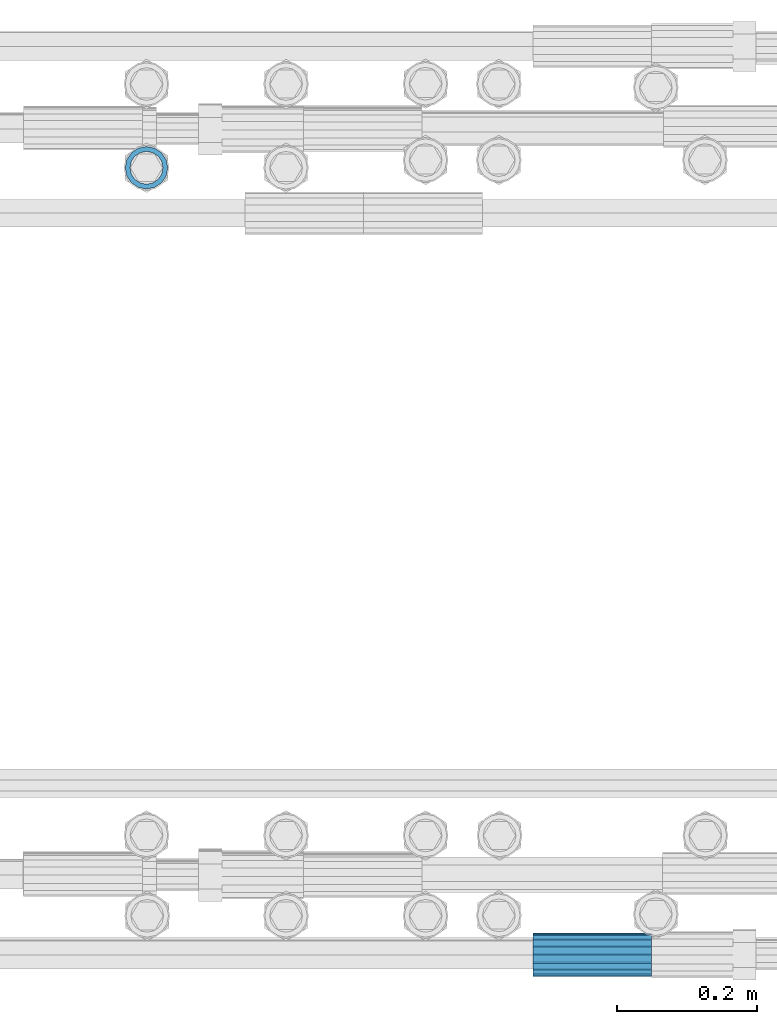
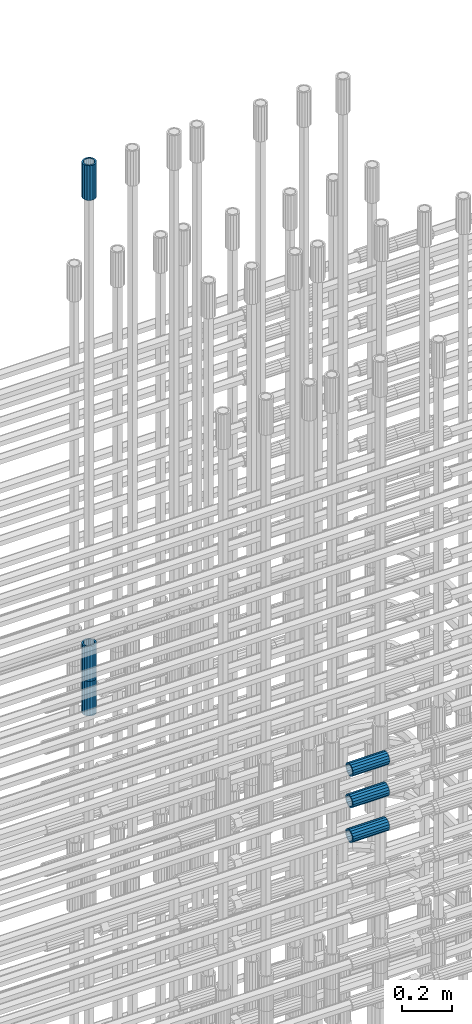
# One storey, part 29 of 119: 6 beams.
"""IFC2X3 building model written with IfcOpenShell, lengths in millimetres."""

from ifc_helpers import new_model, si_unit, frame, origin_with_axes, place, context, subcontext, project, spatial, faceted_brep, material, type_object, element, save


model = new_model("IFC2X3")

# Units and contexts
model_context = context("Model", 3, precision=1e-05, world=origin_with_axes())
body_context = subcontext(model_context, "Body", "Model", "MODEL_VIEW")
ifc_project = project(units=[si_unit("LENGTHUNIT", "METRE", prefix="MILLI"), si_unit("AREAUNIT", "SQUARE_METRE"), si_unit("VOLUMEUNIT", "CUBIC_METRE"), si_unit("MASSUNIT", "GRAM", prefix="KILO"), si_unit("TIMEUNIT", "SECOND"), si_unit("PLANEANGLEUNIT", "RADIAN"), si_unit("SOLIDANGLEUNIT", "STERADIAN"), si_unit("THERMODYNAMICTEMPERATUREUNIT", "DEGREE_CELSIUS"), si_unit("LUMINOUSINTENSITYUNIT", "LUMEN")], contexts=[model_context])

# Site, building, storey
site_placement = place(None, origin_with_axes())
site = spatial("IfcSite", under=ifc_project, at=site_placement, CompositionType="ELEMENT")
building_placement = place(site_placement, origin_with_axes())
building = spatial("IfcBuilding", under=site, at=building_placement, Name="Undefined", CompositionType="ELEMENT")
storey_placement = place(building_placement, origin_with_axes())
storey = spatial("IfcBuildingStorey", under=building, at=storey_placement, Name="Undefined", CompositionType="ELEMENT", Elevation=0.0)

# Beams
ifc_material = material(Name="STEEL/S275")
beam_type = type_object("IfcBeamType", PredefinedType="NOTDEFINED")
beam_1_placement = place(storey_placement, frame((2035124.99756192, 6206225.98580115, 23229.965729164), z_axis=(1.0, 0.0, 0.0), x_axis=(0.0, 0.0, 1.0)))
element("IfcBeam", 1, at=beam_1_placement, inside=storey, type_object=beam_type, material=ifc_material, Name="AG40N", context=body_context, shape_type="Brep", body=[
    faceted_brep([(1.62981450557709e-09, -23.4999999990687, 0.0), (7.45058059692383e-09, -21.7111690142192, 8.99306066057534), (170.000002125278, -21.711168999318, 8.99306066022245), (170.000002127141, -23.4999999844003, -3.66071617463604e-10), (4.65661287307739e-09, -16.6170093587134, 16.6170093578889), (170.000002122484, -16.6170093440451, 16.6170093575288), (1.86264514923096e-09, -8.99306066217832, 21.7111690140277), (170.000002118759, -8.99306064750999, 21.7111690136603), (2.3283064365387e-10, 9.31322574615479e-10, 23.5), (170.000002114102, 1.28056854009628e-08, 23.4999999996485), (-6.51925802230835e-09, 8.99306065868586, 21.7111690140241), (170.00000211224, 8.99306067335419, 21.7111690136639), (-7.45058059692383e-09, 16.6170093561523, 16.6170093578853), (170.000002109446, 16.6170093708206, 16.6170093575324), (-9.31322574615479e-09, 21.711169013055, 8.99306066057534), (170.000002108514, 21.7111690277234, 8.99306066022245), (-1.16415321826935e-09, 23.5000000009313, 0.0), (170.000002108514, 23.5000000144355, -3.66071617463604e-10), (-8.38190317153931e-09, 21.7111690151505, -8.99306066059444), (170.000002110377, 21.7111690300517, -8.9930606609546), (-5.58793544769287e-09, 16.6170093598776, -16.6170093579008), (170.000002113171, 16.6170093745459, -16.6170093582609), (-9.31322574615479e-10, 8.99306066334248, -21.7111690140396), (170.000002115965, 8.99306067801081, -21.7111690143961), (2.3283064365387e-10, 9.31322574615479e-10, -23.5), (170.00000211969, 1.7927959561348e-08, -23.5000000003843), (5.58793544769287e-09, -8.99306065752171, -21.7111690140396), (170.000002123415, -8.99306064285338, -21.7111690143961), (8.38190317153931e-09, -16.6170093549881, -16.6170093579008), (170.000002125278, -16.6170093403198, -16.6170093582646), (9.31322574615479e-09, -21.7111690121237, -8.99306066059444), (170.000002127141, -21.7111689972226, -8.9930606609546), (1.11758708953857e-08, -30.4999999990687, -9.54969436861575e-12), (1.30385160446167e-08, -28.1783257392235, -11.6718446871514), (170.000002129003, -28.1783257243223, -11.6718446875116), (170.000002129935, -30.4999999841675, -3.66071617463604e-10), (1.02445483207703e-08, -21.5667568228673, -21.5667568262129), (170.000002128072, -21.566756808199, -21.5667568265694), (7.45058059692383e-09, -11.6718446831219, -28.1783257416196), (170.000002125278, -11.6718446684536, -28.1783257419834), (3.72529029846191e-09, 3.95812094211578e-09, -30.5000000000277), (170.00000211969, 1.83936208486557e-08, -30.5000000003879), (-9.31322574615479e-10, 11.6718446905725, -28.1783257416232), (170.000002115965, 11.6718447052408, -28.1783257419797), (-6.51925802230835e-09, 21.5667568286881, -21.5667568262093), (170.000002110377, 21.5667568433564, -21.5667568265694), (-9.31322574615479e-09, 28.178325742716, -11.6718446871478), (170.000002108514, 28.1783257573843, -11.6718446875079), (-1.21071934700012e-08, 30.5, -5.91171556152403e-12), (170.000002106652, 30.5000000144355, -3.62433638656512e-10), (-1.21071934700012e-08, 28.1783257401548, 11.6718446871359), (170.00000210572, 28.1783257548232, 11.6718446867794), (-1.02445483207703e-08, 21.5667568240315, 21.5667568261974), (170.000002107583, 21.566756838467, 21.5667568258409), (-7.45058059692383e-09, 11.671844684286, 28.1783257416041), (170.000002110377, 11.6718446989544, 28.178325741244), (-2.79396772384644e-09, -2.56113708019257e-09, 30.5000000000159), (170.000002114102, 1.18743628263474e-08, 30.4999999996558), (1.86264514923096e-09, -11.6718446896411, 28.1783257416114), (170.000002118759, -11.67184467474, 28.178325741244), (7.45058059692383e-09, -21.5667568275239, 21.5667568261974), (170.000002123415, -21.5667568126228, 21.5667568258373), (1.02445483207703e-08, -28.1783257415518, 11.6718446871359), (170.000002127141, -28.1783257271163, 11.6718446867794)], [[[0, 1, 2, 3]], [[1, 4, 5, 2]], [[4, 6, 7, 5]], [[6, 8, 9, 7]], [[8, 10, 11, 9]], [[10, 12, 13, 11]], [[12, 14, 15, 13]], [[14, 16, 17, 15]], [[16, 18, 19, 17]], [[18, 20, 21, 19]], [[20, 22, 23, 21]], [[22, 24, 25, 23]], [[24, 26, 27, 25]], [[26, 28, 29, 27]], [[28, 30, 31, 29]], [[30, 0, 3, 31]], [[32, 33, 34, 35]], [[33, 36, 37, 34]], [[36, 38, 39, 37]], [[38, 40, 41, 39]], [[40, 42, 43, 41]], [[42, 44, 45, 43]], [[44, 46, 47, 45]], [[46, 48, 49, 47]], [[48, 50, 51, 49]], [[50, 52, 53, 51]], [[52, 54, 55, 53]], [[54, 56, 57, 55]], [[56, 58, 59, 57]], [[58, 60, 61, 59]], [[60, 62, 63, 61]], [[62, 32, 35, 63]], [[37, 39, 41, 43, 45, 47, 49, 51, 53, 55, 57, 59, 61, 63, 35, 34], [5, 7, 9, 11, 13, 15, 17, 19, 21, 23, 25, 27, 29, 31, 3, 2]], [[62, 60, 58, 56, 54, 52, 50, 48, 46, 44, 42, 40, 38, 36, 33, 32], [30, 28, 26, 24, 22, 20, 18, 16, 14, 12, 10, 8, 6, 4, 1, 0]]]),
])
beam_2_placement = place(storey_placement, frame((2035124.99756192, 6206225.98580116, 21044.6068583145), z_axis=(-0.99999999999998, 1.98000110685822e-07, 0.0), x_axis=(0.0, 0.0, -1.0)))
element("IfcBeam", 2, at=beam_2_placement, inside=storey, type_object=beam_type, material=ifc_material, Name="AG40N", context=body_context, shape_type="Brep", body=[
    faceted_brep([(1.62981450557709e-09, -23.4999999990687, 0.0), (7.45058059692383e-09, -21.7111690142192, 8.99306066057534), (170.000002125278, -21.711168999318, 8.99306066022245), (170.000002127141, -23.4999999844003, -3.66071617463604e-10), (4.65661287307739e-09, -16.6170093587134, 16.6170093578889), (170.000002122484, -16.6170093440451, 16.6170093575288), (1.86264514923096e-09, -8.99306066217832, 21.7111690140277), (170.000002118759, -8.99306064750999, 21.7111690136603), (2.3283064365387e-10, 9.31322574615479e-10, 23.5), (170.000002114102, 1.28056854009628e-08, 23.4999999996485), (-6.51925802230835e-09, 8.99306065868586, 21.7111690140241), (170.00000211224, 8.99306067335419, 21.7111690136639), (-7.45058059692383e-09, 16.6170093561523, 16.6170093578853), (170.000002109446, 16.6170093708206, 16.6170093575324), (-9.31322574615479e-09, 21.711169013055, 8.99306066057534), (170.000002108514, 21.7111690277234, 8.99306066022245), (-1.16415321826935e-09, 23.5000000009313, 0.0), (170.000002108514, 23.5000000144355, -3.66071617463604e-10), (-8.38190317153931e-09, 21.7111690151505, -8.99306066059444), (170.000002110377, 21.7111690300517, -8.9930606609546), (-5.58793544769287e-09, 16.6170093598776, -16.6170093579008), (170.000002113171, 16.6170093745459, -16.6170093582609), (-9.31322574615479e-10, 8.99306066334248, -21.7111690140396), (170.000002115965, 8.99306067801081, -21.7111690143961), (2.3283064365387e-10, 9.31322574615479e-10, -23.5), (170.00000211969, 1.7927959561348e-08, -23.5000000003843), (5.58793544769287e-09, -8.99306065752171, -21.7111690140396), (170.000002123415, -8.99306064285338, -21.7111690143961), (8.38190317153931e-09, -16.6170093549881, -16.6170093579008), (170.000002125278, -16.6170093403198, -16.6170093582646), (9.31322574615479e-09, -21.7111690121237, -8.99306066059444), (170.000002127141, -21.7111689972226, -8.9930606609546), (1.11758708953857e-08, -30.4999999990687, -9.54969436861575e-12), (1.30385160446167e-08, -28.1783257392235, -11.6718446871514), (170.000002129003, -28.1783257243223, -11.6718446875116), (170.000002129935, -30.4999999841675, -3.66071617463604e-10), (1.02445483207703e-08, -21.5667568228673, -21.5667568262129), (170.000002128072, -21.566756808199, -21.5667568265694), (7.45058059692383e-09, -11.6718446831219, -28.1783257416196), (170.000002125278, -11.6718446684536, -28.1783257419834), (3.72529029846191e-09, 3.95812094211578e-09, -30.5000000000277), (170.00000211969, 1.83936208486557e-08, -30.5000000003879), (-9.31322574615479e-10, 11.6718446905725, -28.1783257416232), (170.000002115965, 11.6718447052408, -28.1783257419797), (-6.51925802230835e-09, 21.5667568286881, -21.5667568262093), (170.000002110377, 21.5667568433564, -21.5667568265694), (-9.31322574615479e-09, 28.178325742716, -11.6718446871478), (170.000002108514, 28.1783257573843, -11.6718446875079), (-1.21071934700012e-08, 30.5, -5.91171556152403e-12), (170.000002106652, 30.5000000144355, -3.62433638656512e-10), (-1.21071934700012e-08, 28.1783257401548, 11.6718446871359), (170.00000210572, 28.1783257548232, 11.6718446867794), (-1.02445483207703e-08, 21.5667568240315, 21.5667568261974), (170.000002107583, 21.566756838467, 21.5667568258409), (-7.45058059692383e-09, 11.671844684286, 28.1783257416041), (170.000002110377, 11.6718446989544, 28.178325741244), (-2.79396772384644e-09, -2.56113708019257e-09, 30.5000000000159), (170.000002114102, 1.18743628263474e-08, 30.4999999996558), (1.86264514923096e-09, -11.6718446896411, 28.1783257416114), (170.000002118759, -11.67184467474, 28.178325741244), (7.45058059692383e-09, -21.5667568275239, 21.5667568261974), (170.000002123415, -21.5667568126228, 21.5667568258373), (1.02445483207703e-08, -28.1783257415518, 11.6718446871359), (170.000002127141, -28.1783257271163, 11.6718446867794)], [[[0, 1, 2, 3]], [[1, 4, 5, 2]], [[4, 6, 7, 5]], [[6, 8, 9, 7]], [[8, 10, 11, 9]], [[10, 12, 13, 11]], [[12, 14, 15, 13]], [[14, 16, 17, 15]], [[16, 18, 19, 17]], [[18, 20, 21, 19]], [[20, 22, 23, 21]], [[22, 24, 25, 23]], [[24, 26, 27, 25]], [[26, 28, 29, 27]], [[28, 30, 31, 29]], [[30, 0, 3, 31]], [[32, 33, 34, 35]], [[33, 36, 37, 34]], [[36, 38, 39, 37]], [[38, 40, 41, 39]], [[40, 42, 43, 41]], [[42, 44, 45, 43]], [[44, 46, 47, 45]], [[46, 48, 49, 47]], [[48, 50, 51, 49]], [[50, 52, 53, 51]], [[52, 54, 55, 53]], [[54, 56, 57, 55]], [[56, 58, 59, 57]], [[58, 60, 61, 59]], [[60, 62, 63, 61]], [[62, 32, 35, 63]], [[37, 39, 41, 43, 45, 47, 49, 51, 53, 55, 57, 59, 61, 63, 35, 34], [5, 7, 9, 11, 13, 15, 17, 19, 21, 23, 25, 27, 29, 31, 3, 2]], [[62, 60, 58, 56, 54, 52, 50, 48, 46, 44, 42, 40, 38, 36, 33, 32], [30, 28, 26, 24, 22, 20, 18, 16, 14, 12, 10, 8, 6, 4, 1, 0]]]),
])
beam_3_placement = place(storey_placement, frame((2035124.99756192, 6206225.98580115, 20704.605729164), z_axis=(1.0, 0.0, 0.0), x_axis=(0.0, 0.0, 1.0)))
element("IfcBeam", 3, at=beam_3_placement, inside=storey, type_object=beam_type, material=ifc_material, Name="AG40N", context=body_context, shape_type="Brep", body=[
    faceted_brep([(1.62981450557709e-09, -23.4999999990687, 0.0), (7.45058059692383e-09, -21.7111690142192, 8.99306066057534), (170.000002125278, -21.711168999318, 8.99306066022245), (170.000002127141, -23.4999999844003, -3.66071617463604e-10), (4.65661287307739e-09, -16.6170093587134, 16.6170093578889), (170.000002122484, -16.6170093440451, 16.6170093575288), (1.86264514923096e-09, -8.99306066217832, 21.7111690140277), (170.000002118759, -8.99306064750999, 21.7111690136603), (2.3283064365387e-10, 9.31322574615479e-10, 23.5), (170.000002114102, 1.28056854009628e-08, 23.4999999996485), (-6.51925802230835e-09, 8.99306065868586, 21.7111690140241), (170.00000211224, 8.99306067335419, 21.7111690136639), (-7.45058059692383e-09, 16.6170093561523, 16.6170093578853), (170.000002109446, 16.6170093708206, 16.6170093575324), (-9.31322574615479e-09, 21.711169013055, 8.99306066057534), (170.000002108514, 21.7111690277234, 8.99306066022245), (-1.16415321826935e-09, 23.5000000009313, 0.0), (170.000002108514, 23.5000000144355, -3.66071617463604e-10), (-8.38190317153931e-09, 21.7111690151505, -8.99306066059444), (170.000002110377, 21.7111690300517, -8.9930606609546), (-5.58793544769287e-09, 16.6170093598776, -16.6170093579008), (170.000002113171, 16.6170093745459, -16.6170093582609), (-9.31322574615479e-10, 8.99306066334248, -21.7111690140396), (170.000002115965, 8.99306067801081, -21.7111690143961), (2.3283064365387e-10, 9.31322574615479e-10, -23.5), (170.00000211969, 1.7927959561348e-08, -23.5000000003843), (5.58793544769287e-09, -8.99306065752171, -21.7111690140396), (170.000002123415, -8.99306064285338, -21.7111690143961), (8.38190317153931e-09, -16.6170093549881, -16.6170093579008), (170.000002125278, -16.6170093403198, -16.6170093582646), (9.31322574615479e-09, -21.7111690121237, -8.99306066059444), (170.000002127141, -21.7111689972226, -8.9930606609546), (1.11758708953857e-08, -30.4999999990687, -9.54969436861575e-12), (1.30385160446167e-08, -28.1783257392235, -11.6718446871514), (170.000002129003, -28.1783257243223, -11.6718446875116), (170.000002129935, -30.4999999841675, -3.66071617463604e-10), (1.02445483207703e-08, -21.5667568228673, -21.5667568262129), (170.000002128072, -21.566756808199, -21.5667568265694), (7.45058059692383e-09, -11.6718446831219, -28.1783257416196), (170.000002125278, -11.6718446684536, -28.1783257419834), (3.72529029846191e-09, 3.95812094211578e-09, -30.5000000000277), (170.00000211969, 1.83936208486557e-08, -30.5000000003879), (-9.31322574615479e-10, 11.6718446905725, -28.1783257416232), (170.000002115965, 11.6718447052408, -28.1783257419797), (-6.51925802230835e-09, 21.5667568286881, -21.5667568262093), (170.000002110377, 21.5667568433564, -21.5667568265694), (-9.31322574615479e-09, 28.178325742716, -11.6718446871478), (170.000002108514, 28.1783257573843, -11.6718446875079), (-1.21071934700012e-08, 30.5, -5.91171556152403e-12), (170.000002106652, 30.5000000144355, -3.62433638656512e-10), (-1.21071934700012e-08, 28.1783257401548, 11.6718446871359), (170.00000210572, 28.1783257548232, 11.6718446867794), (-1.02445483207703e-08, 21.5667568240315, 21.5667568261974), (170.000002107583, 21.566756838467, 21.5667568258409), (-7.45058059692383e-09, 11.671844684286, 28.1783257416041), (170.000002110377, 11.6718446989544, 28.178325741244), (-2.79396772384644e-09, -2.56113708019257e-09, 30.5000000000159), (170.000002114102, 1.18743628263474e-08, 30.4999999996558), (1.86264514923096e-09, -11.6718446896411, 28.1783257416114), (170.000002118759, -11.67184467474, 28.178325741244), (7.45058059692383e-09, -21.5667568275239, 21.5667568261974), (170.000002123415, -21.5667568126228, 21.5667568258373), (1.02445483207703e-08, -28.1783257415518, 11.6718446871359), (170.000002127141, -28.1783257271163, 11.6718446867794)], [[[0, 1, 2, 3]], [[1, 4, 5, 2]], [[4, 6, 7, 5]], [[6, 8, 9, 7]], [[8, 10, 11, 9]], [[10, 12, 13, 11]], [[12, 14, 15, 13]], [[14, 16, 17, 15]], [[16, 18, 19, 17]], [[18, 20, 21, 19]], [[20, 22, 23, 21]], [[22, 24, 25, 23]], [[24, 26, 27, 25]], [[26, 28, 29, 27]], [[28, 30, 31, 29]], [[30, 0, 3, 31]], [[32, 33, 34, 35]], [[33, 36, 37, 34]], [[36, 38, 39, 37]], [[38, 40, 41, 39]], [[40, 42, 43, 41]], [[42, 44, 45, 43]], [[44, 46, 47, 45]], [[46, 48, 49, 47]], [[48, 50, 51, 49]], [[50, 52, 53, 51]], [[52, 54, 55, 53]], [[54, 56, 57, 55]], [[56, 58, 59, 57]], [[58, 60, 61, 59]], [[60, 62, 63, 61]], [[62, 32, 35, 63]], [[37, 39, 41, 43, 45, 47, 49, 51, 53, 55, 57, 59, 61, 63, 35, 34], [5, 7, 9, 11, 13, 15, 17, 19, 21, 23, 25, 27, 29, 31, 3, 2]], [[62, 60, 58, 56, 54, 52, 50, 48, 46, 44, 42, 40, 38, 36, 33, 32], [30, 28, 26, 24, 22, 20, 18, 16, 14, 12, 10, 8, 6, 4, 1, 0]]]),
])
beam_4_placement = place(storey_placement, frame((2035678.66023304, 6205098.98994599, 20587.9894119012), z_axis=(0.0, 0.0, 1.0), x_axis=(1.0, 0.0, 0.0)))
element("IfcBeam", 4, at=beam_4_placement, inside=storey, type_object=beam_type, material=ifc_material, Name="AG40N", context=body_context, shape_type="Brep", body=[
    faceted_brep([(1.62981450557709e-09, -23.4999999990687, 0.0), (7.45058059692383e-09, -21.7111690142192, 8.99306066057534), (170.000002125278, -21.711168999318, 8.99306066022245), (170.000002127141, -23.4999999844003, -3.66071617463604e-10), (4.65661287307739e-09, -16.6170093587134, 16.6170093578889), (170.000002122484, -16.6170093440451, 16.6170093575288), (1.86264514923096e-09, -8.99306066217832, 21.7111690140277), (170.000002118759, -8.99306064750999, 21.7111690136603), (2.3283064365387e-10, 9.31322574615479e-10, 23.5), (170.000002114102, 1.28056854009628e-08, 23.4999999996485), (-6.51925802230835e-09, 8.99306065868586, 21.7111690140241), (170.00000211224, 8.99306067335419, 21.7111690136639), (-7.45058059692383e-09, 16.6170093561523, 16.6170093578853), (170.000002109446, 16.6170093708206, 16.6170093575324), (-9.31322574615479e-09, 21.711169013055, 8.99306066057534), (170.000002108514, 21.7111690277234, 8.99306066022245), (-1.16415321826935e-09, 23.5000000009313, 0.0), (170.000002108514, 23.5000000144355, -3.66071617463604e-10), (-8.38190317153931e-09, 21.7111690151505, -8.99306066059444), (170.000002110377, 21.7111690300517, -8.9930606609546), (-5.58793544769287e-09, 16.6170093598776, -16.6170093579008), (170.000002113171, 16.6170093745459, -16.6170093582609), (-9.31322574615479e-10, 8.99306066334248, -21.7111690140396), (170.000002115965, 8.99306067801081, -21.7111690143961), (2.3283064365387e-10, 9.31322574615479e-10, -23.5), (170.00000211969, 1.7927959561348e-08, -23.5000000003843), (5.58793544769287e-09, -8.99306065752171, -21.7111690140396), (170.000002123415, -8.99306064285338, -21.7111690143961), (8.38190317153931e-09, -16.6170093549881, -16.6170093579008), (170.000002125278, -16.6170093403198, -16.6170093582646), (9.31322574615479e-09, -21.7111690121237, -8.99306066059444), (170.000002127141, -21.7111689972226, -8.9930606609546), (1.11758708953857e-08, -30.4999999990687, -9.54969436861575e-12), (1.30385160446167e-08, -28.1783257392235, -11.6718446871514), (170.000002129003, -28.1783257243223, -11.6718446875116), (170.000002129935, -30.4999999841675, -3.66071617463604e-10), (1.02445483207703e-08, -21.5667568228673, -21.5667568262129), (170.000002128072, -21.566756808199, -21.5667568265694), (7.45058059692383e-09, -11.6718446831219, -28.1783257416196), (170.000002125278, -11.6718446684536, -28.1783257419834), (3.72529029846191e-09, 3.95812094211578e-09, -30.5000000000277), (170.00000211969, 1.83936208486557e-08, -30.5000000003879), (-9.31322574615479e-10, 11.6718446905725, -28.1783257416232), (170.000002115965, 11.6718447052408, -28.1783257419797), (-6.51925802230835e-09, 21.5667568286881, -21.5667568262093), (170.000002110377, 21.5667568433564, -21.5667568265694), (-9.31322574615479e-09, 28.178325742716, -11.6718446871478), (170.000002108514, 28.1783257573843, -11.6718446875079), (-1.21071934700012e-08, 30.5, -5.91171556152403e-12), (170.000002106652, 30.5000000144355, -3.62433638656512e-10), (-1.21071934700012e-08, 28.1783257401548, 11.6718446871359), (170.00000210572, 28.1783257548232, 11.6718446867794), (-1.02445483207703e-08, 21.5667568240315, 21.5667568261974), (170.000002107583, 21.566756838467, 21.5667568258409), (-7.45058059692383e-09, 11.671844684286, 28.1783257416041), (170.000002110377, 11.6718446989544, 28.178325741244), (-2.79396772384644e-09, -2.56113708019257e-09, 30.5000000000159), (170.000002114102, 1.18743628263474e-08, 30.4999999996558), (1.86264514923096e-09, -11.6718446896411, 28.1783257416114), (170.000002118759, -11.67184467474, 28.178325741244), (7.45058059692383e-09, -21.5667568275239, 21.5667568261974), (170.000002123415, -21.5667568126228, 21.5667568258373), (1.02445483207703e-08, -28.1783257415518, 11.6718446871359), (170.000002127141, -28.1783257271163, 11.6718446867794)], [[[0, 1, 2, 3]], [[1, 4, 5, 2]], [[4, 6, 7, 5]], [[6, 8, 9, 7]], [[8, 10, 11, 9]], [[10, 12, 13, 11]], [[12, 14, 15, 13]], [[14, 16, 17, 15]], [[16, 18, 19, 17]], [[18, 20, 21, 19]], [[20, 22, 23, 21]], [[22, 24, 25, 23]], [[24, 26, 27, 25]], [[26, 28, 29, 27]], [[28, 30, 31, 29]], [[30, 0, 3, 31]], [[32, 33, 34, 35]], [[33, 36, 37, 34]], [[36, 38, 39, 37]], [[38, 40, 41, 39]], [[40, 42, 43, 41]], [[42, 44, 45, 43]], [[44, 46, 47, 45]], [[46, 48, 49, 47]], [[48, 50, 51, 49]], [[50, 52, 53, 51]], [[52, 54, 55, 53]], [[54, 56, 57, 55]], [[56, 58, 59, 57]], [[58, 60, 61, 59]], [[60, 62, 63, 61]], [[62, 32, 35, 63]], [[37, 39, 41, 43, 45, 47, 49, 51, 53, 55, 57, 59, 61, 63, 35, 34], [5, 7, 9, 11, 13, 15, 17, 19, 21, 23, 25, 27, 29, 31, 3, 2]], [[62, 60, 58, 56, 54, 52, 50, 48, 46, 44, 42, 40, 38, 36, 33, 32], [30, 28, 26, 24, 22, 20, 18, 16, 14, 12, 10, 8, 6, 4, 1, 0]]]),
])
beam_5_placement = place(storey_placement, frame((2035678.66023304, 6205098.98994599, 20757.9894119012), z_axis=(0.0, 0.0, 1.0), x_axis=(1.0, 0.0, 0.0)))
element("IfcBeam", 5, at=beam_5_placement, inside=storey, type_object=beam_type, material=ifc_material, Name="AG40N", context=body_context, shape_type="Brep", body=[
    faceted_brep([(1.62981450557709e-09, -23.4999999990687, 0.0), (7.45058059692383e-09, -21.7111690142192, 8.99306066057534), (170.000002125278, -21.711168999318, 8.99306066022245), (170.000002127141, -23.4999999844003, -3.66071617463604e-10), (4.65661287307739e-09, -16.6170093587134, 16.6170093578889), (170.000002122484, -16.6170093440451, 16.6170093575288), (1.86264514923096e-09, -8.99306066217832, 21.7111690140277), (170.000002118759, -8.99306064750999, 21.7111690136603), (2.3283064365387e-10, 9.31322574615479e-10, 23.5), (170.000002114102, 1.28056854009628e-08, 23.4999999996485), (-6.51925802230835e-09, 8.99306065868586, 21.7111690140241), (170.00000211224, 8.99306067335419, 21.7111690136639), (-7.45058059692383e-09, 16.6170093561523, 16.6170093578853), (170.000002109446, 16.6170093708206, 16.6170093575324), (-9.31322574615479e-09, 21.711169013055, 8.99306066057534), (170.000002108514, 21.7111690277234, 8.99306066022245), (-1.16415321826935e-09, 23.5000000009313, 0.0), (170.000002108514, 23.5000000144355, -3.66071617463604e-10), (-8.38190317153931e-09, 21.7111690151505, -8.99306066059444), (170.000002110377, 21.7111690300517, -8.9930606609546), (-5.58793544769287e-09, 16.6170093598776, -16.6170093579008), (170.000002113171, 16.6170093745459, -16.6170093582609), (-9.31322574615479e-10, 8.99306066334248, -21.7111690140396), (170.000002115965, 8.99306067801081, -21.7111690143961), (2.3283064365387e-10, 9.31322574615479e-10, -23.5), (170.00000211969, 1.7927959561348e-08, -23.5000000003843), (5.58793544769287e-09, -8.99306065752171, -21.7111690140396), (170.000002123415, -8.99306064285338, -21.7111690143961), (8.38190317153931e-09, -16.6170093549881, -16.6170093579008), (170.000002125278, -16.6170093403198, -16.6170093582646), (9.31322574615479e-09, -21.7111690121237, -8.99306066059444), (170.000002127141, -21.7111689972226, -8.9930606609546), (1.11758708953857e-08, -30.4999999990687, -9.54969436861575e-12), (1.30385160446167e-08, -28.1783257392235, -11.6718446871514), (170.000002129003, -28.1783257243223, -11.6718446875116), (170.000002129935, -30.4999999841675, -3.66071617463604e-10), (1.02445483207703e-08, -21.5667568228673, -21.5667568262129), (170.000002128072, -21.566756808199, -21.5667568265694), (7.45058059692383e-09, -11.6718446831219, -28.1783257416196), (170.000002125278, -11.6718446684536, -28.1783257419834), (3.72529029846191e-09, 3.95812094211578e-09, -30.5000000000277), (170.00000211969, 1.83936208486557e-08, -30.5000000003879), (-9.31322574615479e-10, 11.6718446905725, -28.1783257416232), (170.000002115965, 11.6718447052408, -28.1783257419797), (-6.51925802230835e-09, 21.5667568286881, -21.5667568262093), (170.000002110377, 21.5667568433564, -21.5667568265694), (-9.31322574615479e-09, 28.178325742716, -11.6718446871478), (170.000002108514, 28.1783257573843, -11.6718446875079), (-1.21071934700012e-08, 30.5, -5.91171556152403e-12), (170.000002106652, 30.5000000144355, -3.62433638656512e-10), (-1.21071934700012e-08, 28.1783257401548, 11.6718446871359), (170.00000210572, 28.1783257548232, 11.6718446867794), (-1.02445483207703e-08, 21.5667568240315, 21.5667568261974), (170.000002107583, 21.566756838467, 21.5667568258409), (-7.45058059692383e-09, 11.671844684286, 28.1783257416041), (170.000002110377, 11.6718446989544, 28.178325741244), (-2.79396772384644e-09, -2.56113708019257e-09, 30.5000000000159), (170.000002114102, 1.18743628263474e-08, 30.4999999996558), (1.86264514923096e-09, -11.6718446896411, 28.1783257416114), (170.000002118759, -11.67184467474, 28.178325741244), (7.45058059692383e-09, -21.5667568275239, 21.5667568261974), (170.000002123415, -21.5667568126228, 21.5667568258373), (1.02445483207703e-08, -28.1783257415518, 11.6718446871359), (170.000002127141, -28.1783257271163, 11.6718446867794)], [[[0, 1, 2, 3]], [[1, 4, 5, 2]], [[4, 6, 7, 5]], [[6, 8, 9, 7]], [[8, 10, 11, 9]], [[10, 12, 13, 11]], [[12, 14, 15, 13]], [[14, 16, 17, 15]], [[16, 18, 19, 17]], [[18, 20, 21, 19]], [[20, 22, 23, 21]], [[22, 24, 25, 23]], [[24, 26, 27, 25]], [[26, 28, 29, 27]], [[28, 30, 31, 29]], [[30, 0, 3, 31]], [[32, 33, 34, 35]], [[33, 36, 37, 34]], [[36, 38, 39, 37]], [[38, 40, 41, 39]], [[40, 42, 43, 41]], [[42, 44, 45, 43]], [[44, 46, 47, 45]], [[46, 48, 49, 47]], [[48, 50, 51, 49]], [[50, 52, 53, 51]], [[52, 54, 55, 53]], [[54, 56, 57, 55]], [[56, 58, 59, 57]], [[58, 60, 61, 59]], [[60, 62, 63, 61]], [[62, 32, 35, 63]], [[37, 39, 41, 43, 45, 47, 49, 51, 53, 55, 57, 59, 61, 63, 35, 34], [5, 7, 9, 11, 13, 15, 17, 19, 21, 23, 25, 27, 29, 31, 3, 2]], [[62, 60, 58, 56, 54, 52, 50, 48, 46, 44, 42, 40, 38, 36, 33, 32], [30, 28, 26, 24, 22, 20, 18, 16, 14, 12, 10, 8, 6, 4, 1, 0]]]),
])
beam_6_placement = place(storey_placement, frame((2035678.66023304, 6205097.47994599, 20912.7694122841), z_axis=(0.0, 0.0, 1.0), x_axis=(1.0, 0.0, 0.0)))
element("IfcBeam", 6, at=beam_6_placement, inside=storey, type_object=beam_type, material=ifc_material, Name="AG40N", context=body_context, shape_type="Brep", body=[
    faceted_brep([(1.62981450557709e-09, -23.4999999990687, 0.0), (7.45058059692383e-09, -21.7111690142192, 8.99306066057534), (170.000002125278, -21.711168999318, 8.99306066022245), (170.000002127141, -23.4999999844003, -3.66071617463604e-10), (4.65661287307739e-09, -16.6170093587134, 16.6170093578889), (170.000002122484, -16.6170093440451, 16.6170093575288), (1.86264514923096e-09, -8.99306066217832, 21.7111690140277), (170.000002118759, -8.99306064750999, 21.7111690136603), (2.3283064365387e-10, 9.31322574615479e-10, 23.5), (170.000002114102, 1.28056854009628e-08, 23.4999999996485), (-6.51925802230835e-09, 8.99306065868586, 21.7111690140241), (170.00000211224, 8.99306067335419, 21.7111690136639), (-7.45058059692383e-09, 16.6170093561523, 16.6170093578853), (170.000002109446, 16.6170093708206, 16.6170093575324), (-9.31322574615479e-09, 21.711169013055, 8.99306066057534), (170.000002108514, 21.7111690277234, 8.99306066022245), (-1.16415321826935e-09, 23.5000000009313, 0.0), (170.000002108514, 23.5000000144355, -3.66071617463604e-10), (-8.38190317153931e-09, 21.7111690151505, -8.99306066059444), (170.000002110377, 21.7111690300517, -8.9930606609546), (-5.58793544769287e-09, 16.6170093598776, -16.6170093579008), (170.000002113171, 16.6170093745459, -16.6170093582609), (-9.31322574615479e-10, 8.99306066334248, -21.7111690140396), (170.000002115965, 8.99306067801081, -21.7111690143961), (2.3283064365387e-10, 9.31322574615479e-10, -23.5), (170.00000211969, 1.7927959561348e-08, -23.5000000003843), (5.58793544769287e-09, -8.99306065752171, -21.7111690140396), (170.000002123415, -8.99306064285338, -21.7111690143961), (8.38190317153931e-09, -16.6170093549881, -16.6170093579008), (170.000002125278, -16.6170093403198, -16.6170093582646), (9.31322574615479e-09, -21.7111690121237, -8.99306066059444), (170.000002127141, -21.7111689972226, -8.9930606609546), (1.11758708953857e-08, -30.4999999990687, -9.54969436861575e-12), (1.30385160446167e-08, -28.1783257392235, -11.6718446871514), (170.000002129003, -28.1783257243223, -11.6718446875116), (170.000002129935, -30.4999999841675, -3.66071617463604e-10), (1.02445483207703e-08, -21.5667568228673, -21.5667568262129), (170.000002128072, -21.566756808199, -21.5667568265694), (7.45058059692383e-09, -11.6718446831219, -28.1783257416196), (170.000002125278, -11.6718446684536, -28.1783257419834), (3.72529029846191e-09, 3.95812094211578e-09, -30.5000000000277), (170.00000211969, 1.83936208486557e-08, -30.5000000003879), (-9.31322574615479e-10, 11.6718446905725, -28.1783257416232), (170.000002115965, 11.6718447052408, -28.1783257419797), (-6.51925802230835e-09, 21.5667568286881, -21.5667568262093), (170.000002110377, 21.5667568433564, -21.5667568265694), (-9.31322574615479e-09, 28.178325742716, -11.6718446871478), (170.000002108514, 28.1783257573843, -11.6718446875079), (-1.21071934700012e-08, 30.5, -5.91171556152403e-12), (170.000002106652, 30.5000000144355, -3.62433638656512e-10), (-1.21071934700012e-08, 28.1783257401548, 11.6718446871359), (170.00000210572, 28.1783257548232, 11.6718446867794), (-1.02445483207703e-08, 21.5667568240315, 21.5667568261974), (170.000002107583, 21.566756838467, 21.5667568258409), (-7.45058059692383e-09, 11.671844684286, 28.1783257416041), (170.000002110377, 11.6718446989544, 28.178325741244), (-2.79396772384644e-09, -2.56113708019257e-09, 30.5000000000159), (170.000002114102, 1.18743628263474e-08, 30.4999999996558), (1.86264514923096e-09, -11.6718446896411, 28.1783257416114), (170.000002118759, -11.67184467474, 28.178325741244), (7.45058059692383e-09, -21.5667568275239, 21.5667568261974), (170.000002123415, -21.5667568126228, 21.5667568258373), (1.02445483207703e-08, -28.1783257415518, 11.6718446871359), (170.000002127141, -28.1783257271163, 11.6718446867794)], [[[0, 1, 2, 3]], [[1, 4, 5, 2]], [[4, 6, 7, 5]], [[6, 8, 9, 7]], [[8, 10, 11, 9]], [[10, 12, 13, 11]], [[12, 14, 15, 13]], [[14, 16, 17, 15]], [[16, 18, 19, 17]], [[18, 20, 21, 19]], [[20, 22, 23, 21]], [[22, 24, 25, 23]], [[24, 26, 27, 25]], [[26, 28, 29, 27]], [[28, 30, 31, 29]], [[30, 0, 3, 31]], [[32, 33, 34, 35]], [[33, 36, 37, 34]], [[36, 38, 39, 37]], [[38, 40, 41, 39]], [[40, 42, 43, 41]], [[42, 44, 45, 43]], [[44, 46, 47, 45]], [[46, 48, 49, 47]], [[48, 50, 51, 49]], [[50, 52, 53, 51]], [[52, 54, 55, 53]], [[54, 56, 57, 55]], [[56, 58, 59, 57]], [[58, 60, 61, 59]], [[60, 62, 63, 61]], [[62, 32, 35, 63]], [[37, 39, 41, 43, 45, 47, 49, 51, 53, 55, 57, 59, 61, 63, 35, 34], [5, 7, 9, 11, 13, 15, 17, 19, 21, 23, 25, 27, 29, 31, 3, 2]], [[62, 60, 58, 56, 54, 52, 50, 48, 46, 44, 42, 40, 38, 36, 33, 32], [30, 28, 26, 24, 22, 20, 18, 16, 14, 12, 10, 8, 6, 4, 1, 0]]]),
])

save(model, "model.ifc")
